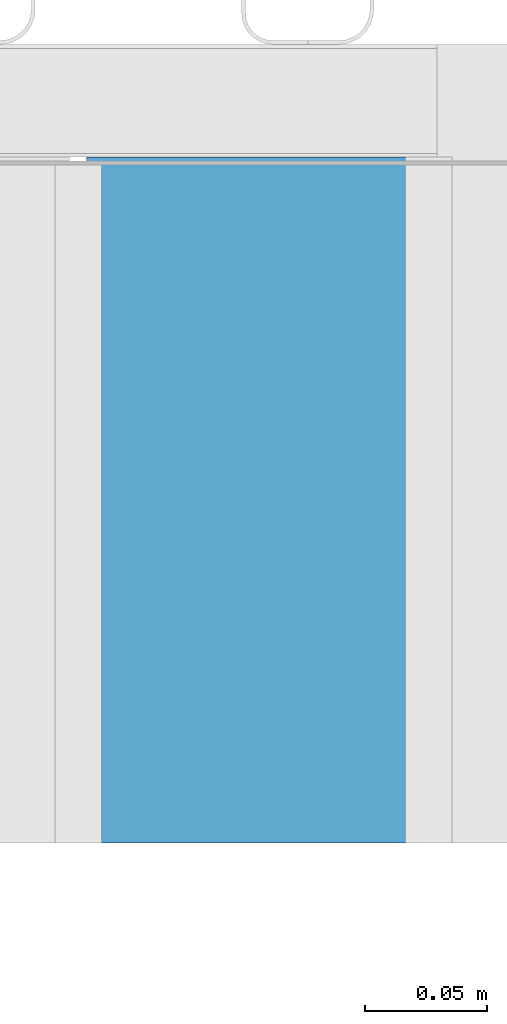
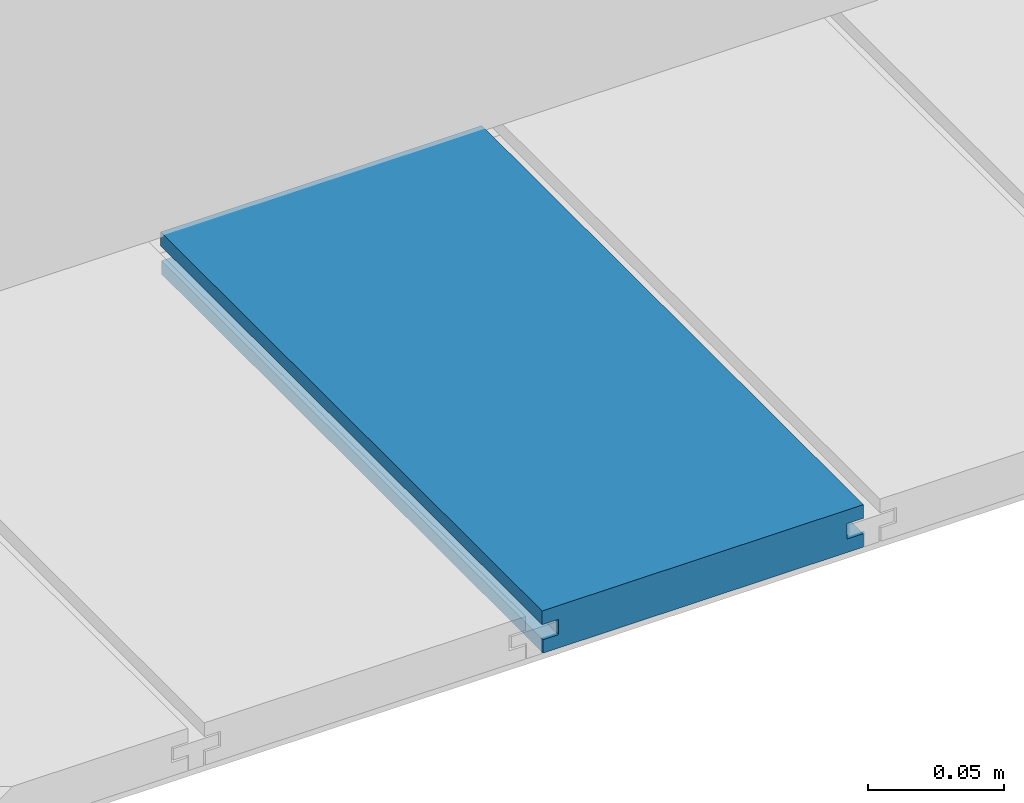
# One storey, part 12 of 33: 1 wall.
"""IFC4 building model written with IfcOpenShell, lengths in feet."""

import ifcopenshell
import ifcopenshell.guid

model = None  # the IFC model being written
_history = None  # IfcOwnerHistory: only IFC2X3 demands one
_inside = {}  # id of a spatial element -> (the spatial element, [elements in it])
_under = {}  # id of a project, library or spatial element -> (it, [spatial elements below it])
_declared = {}  # id of a project -> (the project, [libraries it declares])
_typed = {}  # id of a type object -> (the type object, [elements of that type])
_made_of = {}  # id of a material, layer set ... -> (it, [elements and type objects made of it])


def new_model(schema):
    """Start an empty IFC model of exactly this schema.

    Asked for "IFC4X3", IfcOpenShell would pick the latest addendum, in which some entities
    have other attributes; the version numbers below select the first issue.
    IFC2X3 requires an IfcOwnerHistory on every rooted entity: one is made here for all.
    """
    global model, _history
    if schema == "IFC4X3":
        model = ifcopenshell.file(schema_version=(4, 3, 0, 0))
    else:
        model = ifcopenshell.file(schema=schema)
    _inside.clear()
    _under.clear()
    _declared.clear()
    _typed.clear()
    _made_of.clear()
    _history = None
    if model.schema == "IFC2X3":
        org = make("IfcOrganization", Name="unknown")
        user = make(
            "IfcPersonAndOrganization",
            ThePerson=make("IfcPerson", FamilyName="unknown"),
            TheOrganization=org,
        )
        app = make(
            "IfcApplication",
            ApplicationDeveloper=org,
            Version="unknown",
            ApplicationFullName="unknown",
            ApplicationIdentifier="unknown",
        )
        _history = make(
            "IfcOwnerHistory",
            OwningUser=user,
            OwningApplication=app,
            ChangeAction="ADDED",
            CreationDate=0,
        )
    return model


def make(cls, **values):
    """One entity of the class cls with the attributes given. An attribute that is None is left unset."""
    return model.create_entity(
        cls, **{name: value for name, value in values.items() if value is not None}
    )


def entity(cls, *values):
    """Any entity or typed value of the class cls, its attributes in the order of the schema. None: left unset."""
    e = model.create_entity(cls)
    for i, value in enumerate(values):
        if value is not None:
            e[i] = value
    return e


def rooted(cls, **values):
    """An entity with a GlobalId (a new one), such as an element, a storey or a relation."""
    return make(cls, GlobalId=ifcopenshell.guid.new(), OwnerHistory=_history, **values)


def si_unit(unit_type, name, prefix=None):
    """IfcSIUnit, for example si_unit("LENGTHUNIT", "METRE", prefix="MILLI")."""
    return make("IfcSIUnit", UnitType=unit_type, Prefix=prefix, Name=name)


def converted_unit(unit_type, name, factor, base, dimensions=None, offset=None):
    """IfcConversionBasedUnit, such as the inch: factor (a typed value) times the base unit."""
    return make(
        "IfcConversionBasedUnit"
        if offset is None
        else "IfcConversionBasedUnitWithOffset",
        ConversionOffset=offset,
        Dimensions=None
        if dimensions is None
        else entity("IfcDimensionalExponents", *dimensions),
        UnitType=unit_type,
        Name=name,
        ConversionFactor=make(
            "IfcMeasureWithUnit", ValueComponent=factor, UnitComponent=base
        ),
    )


def derived_unit(unit_type, elements):
    """IfcDerivedUnit: a product of units, each with its exponent."""
    return make(
        "IfcDerivedUnit",
        Elements=[
            make("IfcDerivedUnitElement", Unit=unit, Exponent=power)
            for unit, power in elements
        ],
        UnitType=unit_type,
    )


def assignment(units):
    """IfcUnitAssignment: the units of a project."""
    return None if units is None else make("IfcUnitAssignment", Units=units)


def point(xyz):
    """IfcCartesianPoint."""
    return None if xyz is None else make("IfcCartesianPoint", Coordinates=xyz)


def direction(xyz):
    """IfcDirection."""
    return None if xyz is None else make("IfcDirection", DirectionRatios=xyz)


def frame(location, z_axis=None, x_axis=None):
    """IfcAxis2Placement3D, a coordinate frame: its origin and axes. An axis left out is left unset."""
    return make(
        "IfcAxis2Placement3D",
        Location=point(location),
        Axis=direction(z_axis),
        RefDirection=direction(x_axis),
    )


def origin():
    """The frame at (0, 0, 0) with its axes left unset."""
    return frame((0.0, 0.0, 0.0))


def place(relative_to, where):
    """IfcLocalPlacement: puts the frame where relative to a parent placement (None: the world)."""
    return make(
        "IfcLocalPlacement", PlacementRelTo=relative_to, RelativePlacement=where
    )


def context(
    kind, dimensions, precision=None, world=None, true_north=None, identifier=None
):
    """IfcGeometricRepresentationContext, for example the 3D "Model" context."""
    return make(
        "IfcGeometricRepresentationContext",
        ContextIdentifier=identifier,
        ContextType=kind,
        CoordinateSpaceDimension=dimensions,
        Precision=precision,
        WorldCoordinateSystem=world,
        TrueNorth=true_north,
    )


def subcontext(parent, identifier, kind, view, scale=None):
    """IfcGeometricRepresentationSubContext, for example "Body" below "Model"."""
    return make(
        "IfcGeometricRepresentationSubContext",
        ContextIdentifier=identifier,
        ContextType=kind,
        ParentContext=parent,
        TargetScale=scale,
        TargetView=view,
    )


def project(units=None, contexts=None):
    """IfcProject with its units and contexts."""
    return rooted(
        "IfcProject",
        Name="project",
        RepresentationContexts=contexts,
        UnitsInContext=assignment(units),
    )


def spatial(cls, under=None, at=None, **own):
    """A site, building, storey or space (cls), placed at a placement, below another one or the project."""
    s = rooted(cls, ObjectPlacement=at, **own)
    if under is not None:
        _under.setdefault(under.id(), (under, []))[1].append(s)
    return s


def shape(context_of_items, identifier, shape_type, items):
    """IfcShapeRepresentation: the items that make up one representation, for example the "Body"."""
    return make(
        "IfcShapeRepresentation",
        ContextOfItems=context_of_items,
        RepresentationIdentifier=identifier,
        RepresentationType=shape_type,
        Items=items,
    )


def material(Name=None, Category=None):
    """IfcMaterial."""
    return make("IfcMaterial", Name=Name, Category=Category)


def made_of(thing, what):
    """Note that an element or type object is made of a material, layer set ...; save() writes the relation."""
    if what is not None:
        _made_of.setdefault(what.id(), (what, []))[1].append(thing)
    return thing


def type_object(cls, material=None, **own):
    """A type object (cls), such as IfcWallType, which elements share."""
    return made_of(rooted(cls, **own), material)


def element(
    cls,
    number,
    at=None,
    inside=None,
    cuts=None,
    type_object=None,
    material=None,
    context=None,
    identifier="Body",
    shape_type=None,
    held_by="IfcProductDefinitionShape",
    body=None,
    shapes=None,
    **own,
):
    """One element of the class cls, such as IfcWall. Its Tag is "e" and its number.

    at: its placement. inside: the storey or other place that contains it. cuts: it is an
    opening in that element (IfcRelVoidsElement). A single representation is given by context,
    identifier, shape_type and body (its items); several are given by shapes. held_by: the class
    of the entity that holds the representations. save() writes the other relations.
    """
    e = rooted(cls, Tag="e%d" % number, ObjectPlacement=at, **own)
    if body is not None:
        shapes = [shape(context, identifier, shape_type, body)]
    if shapes is not None:
        e.Representation = make(held_by, Representations=shapes)
    if inside is not None:
        _inside.setdefault(inside.id(), (inside, []))[1].append(e)
    if cuts is not None:
        rooted(
            "IfcRelVoidsElement", RelatingBuildingElement=cuts, RelatedOpeningElement=e
        )
    if type_object is not None:
        _typed.setdefault(type_object.id(), (type_object, []))[1].append(e)
    return made_of(e, material)


def aggregate(whole, parts):
    """IfcRelAggregates: a whole, such as a stair, and the parts it consists of."""
    return rooted("IfcRelAggregates", RelatingObject=whole, RelatedObjects=parts)


def save(model, path):
    """Write the relations noted so far, then the file.

    IfcRelAggregates (storeys below a building ...), IfcRelContainedInSpatialStructure (elements
    in a storey), IfcRelDefinesByType, IfcRelAssociatesMaterial and IfcRelDeclares: one each for
    every whole, place, type object, material and project.
    """
    for whole, parts in _under.values():
        aggregate(whole, parts)
    for where, things in _inside.values():
        rooted(
            "IfcRelContainedInSpatialStructure",
            RelatedElements=things,
            RelatingStructure=where,
        )
    for kind, things in _typed.values():
        rooted("IfcRelDefinesByType", RelatedObjects=things, RelatingType=kind)
    for what, things in _made_of.values():
        rooted("IfcRelAssociatesMaterial", RelatedObjects=things, RelatingMaterial=what)
    for by, libraries in _declared.values():
        rooted("IfcRelDeclares", RelatingContext=by, RelatedDefinitions=libraries)
    model.write(path)


model = new_model("IFC4")

# Units and contexts
model_context = context("Model", 3, precision=0.0001, world=origin(), true_north=direction((6.12303176911189e-17, 1.0)))
body_context = subcontext(model_context, "Body", "Model", "MODEL_VIEW")
ifc_project = project(units=[converted_unit("LENGTHUNIT", "FOOT", entity("IfcRatioMeasure", 0.3048), si_unit("LENGTHUNIT", "METRE"), dimensions=[1, 0, 0, 0, 0, 0, 0]), converted_unit("AREAUNIT", "SQUARE FOOT", entity("IfcRatioMeasure", 0.09290304), si_unit("AREAUNIT", "SQUARE_METRE"), dimensions=[2, 0, 0, 0, 0, 0, 0]), converted_unit("VOLUMEUNIT", "CUBIC FOOT", entity("IfcRatioMeasure", 0.028316846592), si_unit("VOLUMEUNIT", "CUBIC_METRE"), dimensions=[3, 0, 0, 0, 0, 0, 0]), converted_unit("PLANEANGLEUNIT", "DEGREE", entity("IfcRatioMeasure", 0.0174532925199433), si_unit("PLANEANGLEUNIT", "RADIAN"), dimensions=[0, 0, 0, 0, 0, 0, 0]), si_unit("MASSUNIT", "GRAM", prefix="KILO"), derived_unit("MASSDENSITYUNIT", [(si_unit("MASSUNIT", "GRAM", prefix="KILO"), 1), (si_unit("LENGTHUNIT", "METRE"), -3)]), derived_unit("MOMENTOFINERTIAUNIT", [(si_unit("LENGTHUNIT", "METRE"), 4)]), si_unit("TIMEUNIT", "SECOND"), si_unit("FREQUENCYUNIT", "HERTZ"), si_unit("THERMODYNAMICTEMPERATUREUNIT", "DEGREE_CELSIUS"), derived_unit("THERMALTRANSMITTANCEUNIT", [(si_unit("MASSUNIT", "GRAM", prefix="KILO"), 1), (si_unit("THERMODYNAMICTEMPERATUREUNIT", "KELVIN"), -1), (si_unit("TIMEUNIT", "SECOND"), -3)]), derived_unit("VOLUMETRICFLOWRATEUNIT", [(si_unit("LENGTHUNIT", "METRE"), 3), (si_unit("TIMEUNIT", "SECOND"), -1)]), si_unit("ELECTRICCURRENTUNIT", "AMPERE"), si_unit("ELECTRICVOLTAGEUNIT", "VOLT"), si_unit("POWERUNIT", "WATT"), si_unit("FORCEUNIT", "NEWTON"), si_unit("ILLUMINANCEUNIT", "LUX"), si_unit("LUMINOUSFLUXUNIT", "LUMEN"), si_unit("LUMINOUSINTENSITYUNIT", "CANDELA"), derived_unit("USERDEFINED", [(si_unit("MASSUNIT", "GRAM", prefix="KILO"), -1), (si_unit("LENGTHUNIT", "METRE"), -2), (si_unit("TIMEUNIT", "SECOND"), 3), (si_unit("LUMINOUSFLUXUNIT", "LUMEN"), 1)]), derived_unit("LINEARVELOCITYUNIT", [(si_unit("LENGTHUNIT", "METRE"), 1), (si_unit("TIMEUNIT", "SECOND"), -1)]), si_unit("PRESSUREUNIT", "PASCAL"), derived_unit("USERDEFINED", [(si_unit("LENGTHUNIT", "METRE"), -2), (si_unit("MASSUNIT", "GRAM", prefix="KILO"), 1), (si_unit("TIMEUNIT", "SECOND"), -2)]), derived_unit("LINEARFORCEUNIT", [(si_unit("MASSUNIT", "GRAM", prefix="KILO"), 1), (si_unit("LENGTHUNIT", "METRE"), 1), (si_unit("TIMEUNIT", "SECOND"), -2), (si_unit("LENGTHUNIT", "METRE"), -1)]), derived_unit("PLANARFORCEUNIT", [(si_unit("MASSUNIT", "GRAM", prefix="KILO"), 1), (si_unit("LENGTHUNIT", "METRE"), 1), (si_unit("TIMEUNIT", "SECOND"), -2), (si_unit("LENGTHUNIT", "METRE"), -2)])], contexts=[model_context])

# Site, building, storey
site_placement = place(None, origin())
site = spatial("IfcSite", under=ifc_project, at=site_placement, CompositionType="ELEMENT")
building_placement = place(site_placement, origin())
building = spatial("IfcBuilding", under=site, at=building_placement, CompositionType="ELEMENT")
storey_placement = place(building_placement, frame((0.0, 0.0, 10.0)))
storey = spatial("IfcBuildingStorey", under=building, at=storey_placement, Name="2ND FLOOR", CompositionType="ELEMENT", Elevation=10.0000000000002)

# Wall
ifc_material = material(Name="COMPOSITE DECKING W/ HIDDEN FASTENERS", Category="Materials")
wall_type = type_object("IfcWallType", Name="Generic Models 718:Generic Models 1", PredefinedType="NOTDEFINED", material=ifc_material)
wall_placement = place(storey_placement, frame((1489.65235763609, 3.04611392999271, 0.682902157150142), z_axis=(0.0, 0.0, 1.0), x_axis=(0.0, 1.0, 0.0)))
cartesian_point_1 = entity("IfcCartesianPoint", [0.91900333985162, -0.446740923891412, 0.0])
vertex_point_1 = entity("IfcVertexPoint", cartesian_point_1)
cartesian_point_2 = entity("IfcCartesianPoint", [0.919003339851622, -0.00132475379450625, 0.0])
vertex_point_2 = entity("IfcVertexPoint", cartesian_point_2)
ifc_direction_1 = entity("IfcDirection", [0.0, 1.0, 0.0])
edge_curve_1 = entity("IfcEdgeCurve", vertex_point_1, vertex_point_2, entity("IfcTrimmedCurve", entity("IfcLine", cartesian_point_1, entity("IfcVector", ifc_direction_1, 1.0)), [cartesian_point_1], [cartesian_point_2], True, "CARTESIAN"), True)
cartesian_point_3 = entity("IfcCartesianPoint", [0.919003339851622, -0.00132475379450625, 0.0198779960861462])
vertex_point_3 = entity("IfcVertexPoint", cartesian_point_3)
ifc_direction_2 = entity("IfcDirection", [0.0, 0.0, 1.0])
edge_curve_2 = entity("IfcEdgeCurve", vertex_point_2, vertex_point_3, entity("IfcTrimmedCurve", entity("IfcLine", cartesian_point_2, entity("IfcVector", ifc_direction_2, 1.0)), [cartesian_point_2], [cartesian_point_3], True, "CARTESIAN"), True)
cartesian_point_4 = entity("IfcCartesianPoint", [0.919003339851622, -0.0228400010807945, 0.0198779960861462])
vertex_point_4 = entity("IfcVertexPoint", cartesian_point_4)
ifc_direction_3 = entity("IfcDirection", [0.0, -1.0, 0.0])
edge_curve_3 = entity("IfcEdgeCurve", vertex_point_3, vertex_point_4, entity("IfcTrimmedCurve", entity("IfcLine", cartesian_point_3, entity("IfcVector", ifc_direction_3, 1.0)), [cartesian_point_3], [cartesian_point_4], True, "CARTESIAN"), True)
cartesian_point_5 = entity("IfcCartesianPoint", [0.919003339851622, -0.0228400010807945, 0.0422987663426522])
vertex_point_5 = entity("IfcVertexPoint", cartesian_point_5)
edge_curve_4 = entity("IfcEdgeCurve", vertex_point_4, vertex_point_5, entity("IfcTrimmedCurve", entity("IfcLine", cartesian_point_4, entity("IfcVector", ifc_direction_2, 1.0)), [cartesian_point_4], [cartesian_point_5], True, "CARTESIAN"), True)
cartesian_point_6 = entity("IfcCartesianPoint", [0.919003339851622, 0.0, 0.0422987663426522])
vertex_point_6 = entity("IfcVertexPoint", cartesian_point_6)
edge_curve_5 = entity("IfcEdgeCurve", vertex_point_5, vertex_point_6, entity("IfcTrimmedCurve", entity("IfcLine", cartesian_point_5, entity("IfcVector", ifc_direction_1, 1.0)), [cartesian_point_5], [cartesian_point_6], True, "CARTESIAN"), True)
cartesian_point_7 = entity("IfcCartesianPoint", [0.919003339851622, 0.0, 0.0625000000000551])
vertex_point_7 = entity("IfcVertexPoint", cartesian_point_7)
edge_curve_6 = entity("IfcEdgeCurve", vertex_point_6, vertex_point_7, entity("IfcTrimmedCurve", entity("IfcLine", cartesian_point_6, entity("IfcVector", ifc_direction_2, 1.0)), [cartesian_point_6], [cartesian_point_7], True, "CARTESIAN"), True)
cartesian_point_8 = entity("IfcCartesianPoint", [0.91900333985162, -0.446740923891639, 0.0624999999999982])
vertex_point_8 = entity("IfcVertexPoint", cartesian_point_8)
edge_curve_7 = entity("IfcEdgeCurve", vertex_point_7, vertex_point_8, entity("IfcTrimmedCurve", entity("IfcLine", cartesian_point_7, entity("IfcVector", ifc_direction_3, 1.0)), [cartesian_point_7], [cartesian_point_8], True, "CARTESIAN"), True)
cartesian_point_9 = entity("IfcCartesianPoint", [0.91900333985162, -0.446740923891639, 0.0422987663426522])
vertex_point_9 = entity("IfcVertexPoint", cartesian_point_9)
ifc_direction_4 = entity("IfcDirection", [0.0, 0.0, -1.0])
edge_curve_8 = entity("IfcEdgeCurve", vertex_point_8, vertex_point_9, entity("IfcTrimmedCurve", entity("IfcLine", cartesian_point_8, entity("IfcVector", ifc_direction_4, 1.0)), [cartesian_point_8], [cartesian_point_9], True, "CARTESIAN"), True)
cartesian_point_10 = entity("IfcCartesianPoint", [0.91900333985162, -0.423900922810617, 0.0422987663426522])
vertex_point_10 = entity("IfcVertexPoint", cartesian_point_10)
edge_curve_9 = entity("IfcEdgeCurve", vertex_point_9, vertex_point_10, entity("IfcTrimmedCurve", entity("IfcLine", cartesian_point_9, entity("IfcVector", ifc_direction_1, 1.0)), [cartesian_point_9], [cartesian_point_10], True, "CARTESIAN"), True)
cartesian_point_11 = entity("IfcCartesianPoint", [0.91900333985162, -0.423900922810617, 0.0198779960861462])
vertex_point_11 = entity("IfcVertexPoint", cartesian_point_11)
edge_curve_10 = entity("IfcEdgeCurve", vertex_point_10, vertex_point_11, entity("IfcTrimmedCurve", entity("IfcLine", cartesian_point_10, entity("IfcVector", ifc_direction_4, 1.0)), [cartesian_point_10], [cartesian_point_11], True, "CARTESIAN"), True)
cartesian_point_12 = entity("IfcCartesianPoint", [0.91900333985162, -0.446740923891412, 0.0198779960861462])
vertex_point_12 = entity("IfcVertexPoint", cartesian_point_12)
edge_curve_11 = entity("IfcEdgeCurve", vertex_point_11, vertex_point_12, entity("IfcTrimmedCurve", entity("IfcLine", cartesian_point_11, entity("IfcVector", ifc_direction_3, 1.0)), [cartesian_point_11], [cartesian_point_12], True, "CARTESIAN"), True)
edge_curve_12 = entity("IfcEdgeCurve", vertex_point_12, vertex_point_1, entity("IfcTrimmedCurve", entity("IfcLine", cartesian_point_12, entity("IfcVector", ifc_direction_4, 1.0)), [cartesian_point_12], [cartesian_point_1], True, "CARTESIAN"), True)
ifc_direction_5 = entity("IfcDirection", [1.0, 0.0, 0.0])
cartesian_point_13 = entity("IfcCartesianPoint", [0.0, -0.446740923891412, 0.0])
vertex_point_13 = entity("IfcVertexPoint", cartesian_point_13)
cartesian_point_14 = entity("IfcCartesianPoint", [0.0, -0.446740923891412, 0.0198779960861462])
vertex_point_14 = entity("IfcVertexPoint", cartesian_point_14)
edge_curve_13 = entity("IfcEdgeCurve", vertex_point_13, vertex_point_14, entity("IfcTrimmedCurve", entity("IfcLine", cartesian_point_13, entity("IfcVector", ifc_direction_2, 1.0)), [cartesian_point_13], [cartesian_point_14], True, "CARTESIAN"), True)
cartesian_point_15 = entity("IfcCartesianPoint", [0.0, -0.423900922810617, 0.0198779960861462])
vertex_point_15 = entity("IfcVertexPoint", cartesian_point_15)
edge_curve_14 = entity("IfcEdgeCurve", vertex_point_14, vertex_point_15, entity("IfcTrimmedCurve", entity("IfcLine", cartesian_point_14, entity("IfcVector", ifc_direction_1, 1.0)), [cartesian_point_14], [cartesian_point_15], True, "CARTESIAN"), True)
cartesian_point_16 = entity("IfcCartesianPoint", [0.0, -0.423900922810617, 0.0422987663426522])
vertex_point_16 = entity("IfcVertexPoint", cartesian_point_16)
edge_curve_15 = entity("IfcEdgeCurve", vertex_point_15, vertex_point_16, entity("IfcTrimmedCurve", entity("IfcLine", cartesian_point_15, entity("IfcVector", ifc_direction_2, 1.0)), [cartesian_point_15], [cartesian_point_16], True, "CARTESIAN"), True)
cartesian_point_17 = entity("IfcCartesianPoint", [0.0, -0.446740923891639, 0.0422987663426522])
vertex_point_17 = entity("IfcVertexPoint", cartesian_point_17)
edge_curve_16 = entity("IfcEdgeCurve", vertex_point_16, vertex_point_17, entity("IfcTrimmedCurve", entity("IfcLine", cartesian_point_16, entity("IfcVector", ifc_direction_3, 1.0)), [cartesian_point_16], [cartesian_point_17], True, "CARTESIAN"), True)
cartesian_point_18 = entity("IfcCartesianPoint", [0.0, -0.446740923891639, 0.0624999999999982])
vertex_point_18 = entity("IfcVertexPoint", cartesian_point_18)
edge_curve_17 = entity("IfcEdgeCurve", vertex_point_17, vertex_point_18, entity("IfcTrimmedCurve", entity("IfcLine", cartesian_point_17, entity("IfcVector", ifc_direction_2, 1.0)), [cartesian_point_17], [cartesian_point_18], True, "CARTESIAN"), True)
cartesian_point_19 = entity("IfcCartesianPoint", [0.0, 0.0, 0.0625000000000551])
vertex_point_19 = entity("IfcVertexPoint", cartesian_point_19)
edge_curve_18 = entity("IfcEdgeCurve", vertex_point_18, vertex_point_19, entity("IfcTrimmedCurve", entity("IfcLine", cartesian_point_18, entity("IfcVector", ifc_direction_1, 1.0)), [cartesian_point_18], [cartesian_point_19], True, "CARTESIAN"), True)
cartesian_point_20 = entity("IfcCartesianPoint", [0.0, 0.0, 0.0422987663426522])
vertex_point_20 = entity("IfcVertexPoint", cartesian_point_20)
edge_curve_19 = entity("IfcEdgeCurve", vertex_point_19, vertex_point_20, entity("IfcTrimmedCurve", entity("IfcLine", cartesian_point_19, entity("IfcVector", ifc_direction_4, 1.0)), [cartesian_point_19], [cartesian_point_20], True, "CARTESIAN"), True)
cartesian_point_21 = entity("IfcCartesianPoint", [0.0, -0.0228400010807945, 0.0422987663426522])
vertex_point_21 = entity("IfcVertexPoint", cartesian_point_21)
edge_curve_20 = entity("IfcEdgeCurve", vertex_point_20, vertex_point_21, entity("IfcTrimmedCurve", entity("IfcLine", cartesian_point_20, entity("IfcVector", ifc_direction_3, 1.0)), [cartesian_point_20], [cartesian_point_21], True, "CARTESIAN"), True)
cartesian_point_22 = entity("IfcCartesianPoint", [0.0, -0.0228400010807945, 0.0198779960861462])
vertex_point_22 = entity("IfcVertexPoint", cartesian_point_22)
edge_curve_21 = entity("IfcEdgeCurve", vertex_point_21, vertex_point_22, entity("IfcTrimmedCurve", entity("IfcLine", cartesian_point_21, entity("IfcVector", ifc_direction_4, 1.0)), [cartesian_point_21], [cartesian_point_22], True, "CARTESIAN"), True)
cartesian_point_23 = entity("IfcCartesianPoint", [0.0, -0.00132475379450625, 0.0198779960861462])
vertex_point_23 = entity("IfcVertexPoint", cartesian_point_23)
edge_curve_22 = entity("IfcEdgeCurve", vertex_point_22, vertex_point_23, entity("IfcTrimmedCurve", entity("IfcLine", cartesian_point_22, entity("IfcVector", ifc_direction_1, 1.0)), [cartesian_point_22], [cartesian_point_23], True, "CARTESIAN"), True)
cartesian_point_24 = entity("IfcCartesianPoint", [0.0, -0.00132475379450625, 0.0])
vertex_point_24 = entity("IfcVertexPoint", cartesian_point_24)
edge_curve_23 = entity("IfcEdgeCurve", vertex_point_23, vertex_point_24, entity("IfcTrimmedCurve", entity("IfcLine", cartesian_point_23, entity("IfcVector", ifc_direction_4, 1.0)), [cartesian_point_23], [cartesian_point_24], True, "CARTESIAN"), True)
edge_curve_24 = entity("IfcEdgeCurve", vertex_point_24, vertex_point_13, entity("IfcTrimmedCurve", entity("IfcLine", cartesian_point_24, entity("IfcVector", ifc_direction_3, 1.0)), [cartesian_point_24], [cartesian_point_13], True, "CARTESIAN"), True)
ifc_direction_6 = entity("IfcDirection", [-1.0, 0.0, 0.0])
edge_curve_25 = entity("IfcEdgeCurve", vertex_point_13, vertex_point_1, entity("IfcTrimmedCurve", entity("IfcLine", cartesian_point_13, entity("IfcVector", ifc_direction_5, 1.0)), [cartesian_point_13], [cartesian_point_1], True, "CARTESIAN"), True)
edge_curve_26 = entity("IfcEdgeCurve", vertex_point_12, vertex_point_14, entity("IfcTrimmedCurve", entity("IfcLine", cartesian_point_14, entity("IfcVector", ifc_direction_6, 1.0)), [cartesian_point_12], [cartesian_point_14], True, "CARTESIAN"), True)
edge_curve_27 = entity("IfcEdgeCurve", vertex_point_18, vertex_point_8, entity("IfcTrimmedCurve", entity("IfcLine", cartesian_point_18, entity("IfcVector", ifc_direction_5, 1.0)), [cartesian_point_18], [cartesian_point_8], True, "CARTESIAN"), True)
edge_curve_28 = entity("IfcEdgeCurve", vertex_point_7, vertex_point_19, entity("IfcTrimmedCurve", entity("IfcLine", cartesian_point_19, entity("IfcVector", ifc_direction_6, 1.0)), [cartesian_point_7], [cartesian_point_19], True, "CARTESIAN"), True)
edge_curve_29 = entity("IfcEdgeCurve", vertex_point_6, vertex_point_20, entity("IfcTrimmedCurve", entity("IfcLine", cartesian_point_20, entity("IfcVector", ifc_direction_6, 1.0)), [cartesian_point_6], [cartesian_point_20], True, "CARTESIAN"), True)
edge_curve_30 = entity("IfcEdgeCurve", vertex_point_24, vertex_point_2, entity("IfcTrimmedCurve", entity("IfcLine", cartesian_point_24, entity("IfcVector", ifc_direction_5, 1.0)), [cartesian_point_24], [cartesian_point_2], True, "CARTESIAN"), True)
edge_curve_31 = entity("IfcEdgeCurve", vertex_point_17, vertex_point_9, entity("IfcTrimmedCurve", entity("IfcLine", cartesian_point_17, entity("IfcVector", ifc_direction_5, 1.0)), [cartesian_point_17], [cartesian_point_9], True, "CARTESIAN"), True)
edge_curve_32 = entity("IfcEdgeCurve", vertex_point_5, vertex_point_21, entity("IfcTrimmedCurve", entity("IfcLine", cartesian_point_21, entity("IfcVector", ifc_direction_6, 1.0)), [cartesian_point_5], [cartesian_point_21], True, "CARTESIAN"), True)
edge_curve_33 = entity("IfcEdgeCurve", vertex_point_4, vertex_point_22, entity("IfcTrimmedCurve", entity("IfcLine", cartesian_point_22, entity("IfcVector", ifc_direction_6, 1.0)), [cartesian_point_4], [cartesian_point_22], True, "CARTESIAN"), True)
edge_curve_34 = entity("IfcEdgeCurve", vertex_point_3, vertex_point_23, entity("IfcTrimmedCurve", entity("IfcLine", cartesian_point_23, entity("IfcVector", ifc_direction_6, 1.0)), [cartesian_point_3], [cartesian_point_23], True, "CARTESIAN"), True)
edge_curve_35 = entity("IfcEdgeCurve", vertex_point_11, vertex_point_15, entity("IfcTrimmedCurve", entity("IfcLine", cartesian_point_15, entity("IfcVector", ifc_direction_6, 1.0)), [cartesian_point_11], [cartesian_point_15], True, "CARTESIAN"), True)
edge_curve_36 = entity("IfcEdgeCurve", vertex_point_10, vertex_point_16, entity("IfcTrimmedCurve", entity("IfcLine", cartesian_point_16, entity("IfcVector", ifc_direction_6, 1.0)), [cartesian_point_10], [cartesian_point_16], True, "CARTESIAN"), True)
element("IfcWall", 1, at=wall_placement, inside=storey, type_object=wall_type, material=ifc_material, Name="Generic Models 718:Generic Models 1", ObjectType="Generic Models 718:Generic Models 1", PredefinedType="NOTDEFINED", context=body_context, shape_type="AdvancedBrep", body=[
    entity("IfcAdvancedBrep", entity("IfcClosedShell", [entity("IfcAdvancedFace", [entity("IfcFaceOuterBound", entity("IfcEdgeLoop", [entity("IfcOrientedEdge", None, None, edge_curve_1, True), entity("IfcOrientedEdge", None, None, edge_curve_2, True), entity("IfcOrientedEdge", None, None, edge_curve_3, True), entity("IfcOrientedEdge", None, None, edge_curve_4, True), entity("IfcOrientedEdge", None, None, edge_curve_5, True), entity("IfcOrientedEdge", None, None, edge_curve_6, True), entity("IfcOrientedEdge", None, None, edge_curve_7, True), entity("IfcOrientedEdge", None, None, edge_curve_8, True), entity("IfcOrientedEdge", None, None, edge_curve_9, True), entity("IfcOrientedEdge", None, None, edge_curve_10, True), entity("IfcOrientedEdge", None, None, edge_curve_11, True), entity("IfcOrientedEdge", None, None, edge_curve_12, True)]), True)], entity("IfcPlane", entity("IfcAxis2Placement3D", entity("IfcCartesianPoint", [0.91900333985162, -0.446740923891412, -0.0208333333328241]), ifc_direction_5, ifc_direction_4)), True), entity("IfcAdvancedFace", [entity("IfcFaceOuterBound", entity("IfcEdgeLoop", [entity("IfcOrientedEdge", None, None, edge_curve_13, True), entity("IfcOrientedEdge", None, None, edge_curve_14, True), entity("IfcOrientedEdge", None, None, edge_curve_15, True), entity("IfcOrientedEdge", None, None, edge_curve_16, True), entity("IfcOrientedEdge", None, None, edge_curve_17, True), entity("IfcOrientedEdge", None, None, edge_curve_18, True), entity("IfcOrientedEdge", None, None, edge_curve_19, True), entity("IfcOrientedEdge", None, None, edge_curve_20, True), entity("IfcOrientedEdge", None, None, edge_curve_21, True), entity("IfcOrientedEdge", None, None, edge_curve_22, True), entity("IfcOrientedEdge", None, None, edge_curve_23, True), entity("IfcOrientedEdge", None, None, edge_curve_24, True)]), True)], entity("IfcPlane", entity("IfcAxis2Placement3D", entity("IfcCartesianPoint", [0.0, -0.446740923891412, -0.0208333333328241]), ifc_direction_6, ifc_direction_2)), True), entity("IfcAdvancedFace", [entity("IfcFaceOuterBound", entity("IfcEdgeLoop", [entity("IfcOrientedEdge", None, None, edge_curve_13, False), entity("IfcOrientedEdge", None, None, edge_curve_25, True), entity("IfcOrientedEdge", None, None, edge_curve_12, False), entity("IfcOrientedEdge", None, None, edge_curve_26, True)]), True)], entity("IfcPlane", entity("IfcAxis2Placement3D", cartesian_point_13, ifc_direction_3, ifc_direction_5)), True), entity("IfcAdvancedFace", [entity("IfcFaceOuterBound", entity("IfcEdgeLoop", [entity("IfcOrientedEdge", None, None, edge_curve_18, False), entity("IfcOrientedEdge", None, None, edge_curve_27, True), entity("IfcOrientedEdge", None, None, edge_curve_7, False), entity("IfcOrientedEdge", None, None, edge_curve_28, True)]), True)], entity("IfcPlane", entity("IfcAxis2Placement3D", cartesian_point_18, ifc_direction_2, ifc_direction_5)), True), entity("IfcAdvancedFace", [entity("IfcFaceOuterBound", entity("IfcEdgeLoop", [entity("IfcOrientedEdge", None, None, edge_curve_19, False), entity("IfcOrientedEdge", None, None, edge_curve_28, False), entity("IfcOrientedEdge", None, None, edge_curve_6, False), entity("IfcOrientedEdge", None, None, edge_curve_29, True)]), True)], entity("IfcPlane", entity("IfcAxis2Placement3D", cartesian_point_19, ifc_direction_1, ifc_direction_5)), True), entity("IfcAdvancedFace", [entity("IfcFaceOuterBound", entity("IfcEdgeLoop", [entity("IfcOrientedEdge", None, None, edge_curve_24, False), entity("IfcOrientedEdge", None, None, edge_curve_30, True), entity("IfcOrientedEdge", None, None, edge_curve_1, False), entity("IfcOrientedEdge", None, None, edge_curve_25, False)]), True)], entity("IfcPlane", entity("IfcAxis2Placement3D", cartesian_point_24, ifc_direction_4, ifc_direction_5)), True), entity("IfcAdvancedFace", [entity("IfcFaceOuterBound", entity("IfcEdgeLoop", [entity("IfcOrientedEdge", None, None, edge_curve_17, False), entity("IfcOrientedEdge", None, None, edge_curve_31, True), entity("IfcOrientedEdge", None, None, edge_curve_8, False), entity("IfcOrientedEdge", None, None, edge_curve_27, False)]), True)], entity("IfcPlane", entity("IfcAxis2Placement3D", cartesian_point_17, ifc_direction_3, ifc_direction_5)), True), entity("IfcAdvancedFace", [entity("IfcFaceOuterBound", entity("IfcEdgeLoop", [entity("IfcOrientedEdge", None, None, edge_curve_20, False), entity("IfcOrientedEdge", None, None, edge_curve_29, False), entity("IfcOrientedEdge", None, None, edge_curve_5, False), entity("IfcOrientedEdge", None, None, edge_curve_32, True)]), True)], entity("IfcPlane", entity("IfcAxis2Placement3D", cartesian_point_20, ifc_direction_4, ifc_direction_5)), True), entity("IfcAdvancedFace", [entity("IfcFaceOuterBound", entity("IfcEdgeLoop", [entity("IfcOrientedEdge", None, None, edge_curve_21, False), entity("IfcOrientedEdge", None, None, edge_curve_32, False), entity("IfcOrientedEdge", None, None, edge_curve_4, False), entity("IfcOrientedEdge", None, None, edge_curve_33, True)]), True)], entity("IfcPlane", entity("IfcAxis2Placement3D", cartesian_point_21, ifc_direction_1, ifc_direction_5)), True), entity("IfcAdvancedFace", [entity("IfcFaceOuterBound", entity("IfcEdgeLoop", [entity("IfcOrientedEdge", None, None, edge_curve_22, False), entity("IfcOrientedEdge", None, None, edge_curve_33, False), entity("IfcOrientedEdge", None, None, edge_curve_3, False), entity("IfcOrientedEdge", None, None, edge_curve_34, True)]), True)], entity("IfcPlane", entity("IfcAxis2Placement3D", cartesian_point_22, ifc_direction_2, ifc_direction_5)), True), entity("IfcAdvancedFace", [entity("IfcFaceOuterBound", entity("IfcEdgeLoop", [entity("IfcOrientedEdge", None, None, edge_curve_23, False), entity("IfcOrientedEdge", None, None, edge_curve_34, False), entity("IfcOrientedEdge", None, None, edge_curve_2, False), entity("IfcOrientedEdge", None, None, edge_curve_30, False)]), True)], entity("IfcPlane", entity("IfcAxis2Placement3D", cartesian_point_23, ifc_direction_1, ifc_direction_5)), True), entity("IfcAdvancedFace", [entity("IfcFaceOuterBound", entity("IfcEdgeLoop", [entity("IfcOrientedEdge", None, None, edge_curve_14, False), entity("IfcOrientedEdge", None, None, edge_curve_26, False), entity("IfcOrientedEdge", None, None, edge_curve_11, False), entity("IfcOrientedEdge", None, None, edge_curve_35, True)]), True)], entity("IfcPlane", entity("IfcAxis2Placement3D", cartesian_point_14, ifc_direction_2, ifc_direction_5)), True), entity("IfcAdvancedFace", [entity("IfcFaceOuterBound", entity("IfcEdgeLoop", [entity("IfcOrientedEdge", None, None, edge_curve_15, False), entity("IfcOrientedEdge", None, None, edge_curve_35, False), entity("IfcOrientedEdge", None, None, edge_curve_10, False), entity("IfcOrientedEdge", None, None, edge_curve_36, True)]), True)], entity("IfcPlane", entity("IfcAxis2Placement3D", cartesian_point_15, ifc_direction_3, ifc_direction_5)), True), entity("IfcAdvancedFace", [entity("IfcFaceOuterBound", entity("IfcEdgeLoop", [entity("IfcOrientedEdge", None, None, edge_curve_16, False), entity("IfcOrientedEdge", None, None, edge_curve_36, False), entity("IfcOrientedEdge", None, None, edge_curve_9, False), entity("IfcOrientedEdge", None, None, edge_curve_31, False)]), True)], entity("IfcPlane", entity("IfcAxis2Placement3D", cartesian_point_16, ifc_direction_4, ifc_direction_5)), True)])),
])

save(model, "model.ifc")
